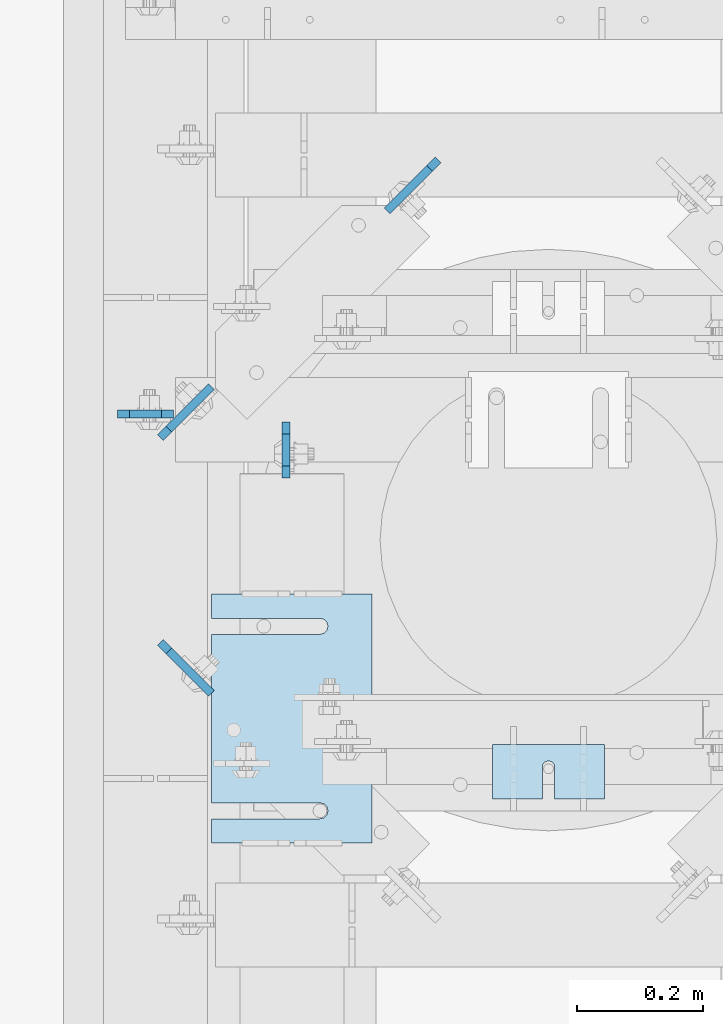
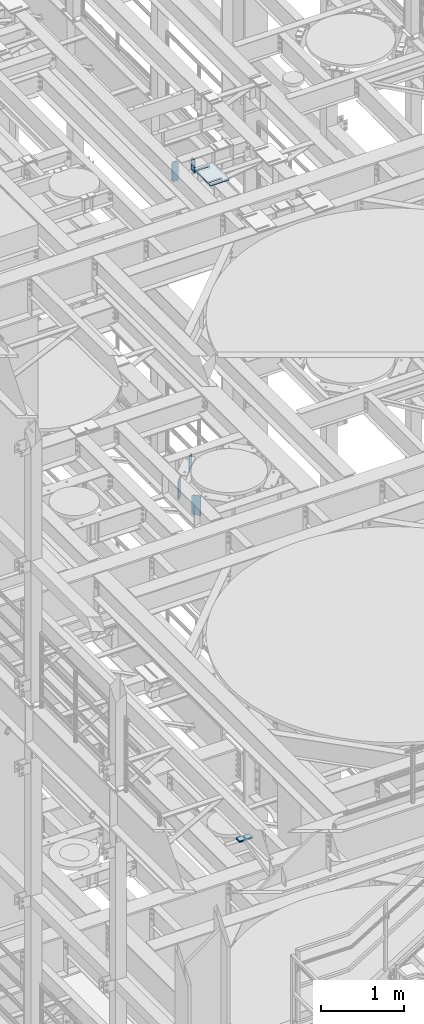
# One storey, part 1637 of 1876: 12 plates, 11 elements without a shape of their own.
"""IFC2X3 building model written with IfcOpenShell, lengths in millimetres."""

from ifc_helpers import new_model, si_unit, frame, origin_with_axes, place, context, subcontext, project, spatial, faceted_brep, material, type_object, element, aggregate, save


model = new_model("IFC2X3")

# Units and contexts
model_context = context("Model", 3, precision=1e-05, world=origin_with_axes())
body_context = subcontext(model_context, "Body", "Model", "MODEL_VIEW")
ifc_project = project(units=[si_unit("LENGTHUNIT", "METRE", prefix="MILLI"), si_unit("AREAUNIT", "SQUARE_METRE"), si_unit("VOLUMEUNIT", "CUBIC_METRE"), si_unit("MASSUNIT", "GRAM", prefix="KILO"), si_unit("TIMEUNIT", "SECOND"), si_unit("PLANEANGLEUNIT", "RADIAN"), si_unit("SOLIDANGLEUNIT", "STERADIAN"), si_unit("THERMODYNAMICTEMPERATUREUNIT", "DEGREE_CELSIUS"), si_unit("LUMINOUSINTENSITYUNIT", "LUMEN")], contexts=[model_context])

# Site, building, storey
site_placement = place(None, origin_with_axes())
site = spatial("IfcSite", under=ifc_project, at=site_placement, CompositionType="ELEMENT")
building_placement = place(site_placement, origin_with_axes())
building = spatial("IfcBuilding", under=site, at=building_placement, Name="Undefined", CompositionType="ELEMENT")
storey_placement = place(building_placement, origin_with_axes())
storey = spatial("IfcBuildingStorey", under=building, at=storey_placement, Name="Undefined", CompositionType="ELEMENT", Elevation=0.0)

# Assembly, plate
assembly_1_placement = place(storey_placement, origin_with_axes())
assembly_1 = element("IfcElementAssembly", 1, at=assembly_1_placement, inside=storey, Name="SHIM PLATE", AssemblyPlace="NOTDEFINED", PredefinedType="RIGID_FRAME")
ifc_material = material(Name="STEEL/A36")
plate_type_1 = type_object("IfcPlateType", PredefinedType="NOTDEFINED")
plate_1_placement = place(assembly_1_placement, frame((4508.50086692662, 2117.72232666016, 8158.1625), z_axis=(0.0, -1.0, 0.0), x_axis=(-1.0, 0.0, 0.0)))
plate_1 = element("IfcPlate", 2, at=plate_1_placement, type_object=plate_type_1, material=ifc_material, Name="SHIM PLATE", context=body_context, shape_type="Brep", body=[
    faceted_brep([(79.3754980174272, -4.76249999999982, 85.7959442138672), (79.3816870943956, -4.76249999999982, 38.1942513122049), (79.3816870943956, 4.76249999999982, 38.1942513122049), (79.3754980174272, 4.76249999999982, 85.7959442138672), (79.5339603115162, -4.76249999999982, 32.1592455981272), (79.5339603115162, 4.76249999999982, 32.1592455981272), (83.1558903074947, -4.76249999999982, 27.3295350264834), (83.1558903074947, 4.76249999999982, 27.3295350264834), (88.9066875296403, -4.76249999999982, 25.4930132021109), (88.9066875296403, 4.76249999999982, 25.4930132021109), (94.6574845388659, -4.76249999999982, 27.3295356932131), (94.6574845388659, 4.76249999999982, 27.3295356932131), (98.2794139749021, -4.76249999999982, 32.1592466847724), (98.2794139749021, 4.76249999999982, 32.1592466847724), (98.4316864923421, -4.76249999999982, 38.1942524165047), (98.4316864923421, 4.76249999999982, 38.1942524165047), (98.4254974155128, -4.76249999999982, 85.7959442138635), (98.4254974155128, 4.76249999999982, 85.7959442138672), (0.0, -4.76249999999982, 0.0), (0.0, -4.76249999999982, 85.7959442138672), (0.0, 4.76249999999982, 85.7959442138672), (0.0, 4.76249999999982, 0.0), (177.800994873047, -4.76249999999982, 0.0), (177.800994873047, 4.76249999999982, 0.0), (177.800994873047, -4.76249999999982, 85.7959442138672), (177.800994873047, 4.76249999999982, 85.7959442138672)], [[[0, 1, 2, 3]], [[4, 5, 2, 1]], [[6, 7, 5, 4]], [[8, 9, 7, 6]], [[10, 11, 9, 8]], [[12, 13, 11, 10]], [[14, 15, 13, 12]], [[16, 17, 15, 14]], [[18, 19, 20, 21]], [[22, 18, 21, 23]], [[24, 22, 23, 25]], [[12, 10, 8, 6, 4, 1, 0, 19, 18, 22, 24, 16, 14]], [[20, 19, 0, 3]], [[25, 23, 21, 20, 3, 2, 5, 7, 9, 11, 13, 15, 17]], [[24, 25, 17, 16]]]),
])
aggregate(assembly_1, [plate_1])

assembly_2_placement = place(storey_placement, origin_with_axes())
assembly_2 = element("IfcElementAssembly", 3, at=assembly_2_placement, inside=storey, Name="BEAM", AssemblyPlace="NOTDEFINED", PredefinedType="RIGID_FRAME")
plate_type_2 = type_object("IfcPlateType", PredefinedType="NOTDEFINED")
plate_2_placement = place(assembly_2_placement, frame((4003.67517775661, 2628.8994140625, 17786.35), z_axis=(0.0, 0.0, 1.0), x_axis=(0.0, -1.0, 0.0)))
plate_2 = element("IfcPlate", 4, at=plate_2_placement, type_object=plate_type_2, material=ifc_material, Name="PLATE", context=body_context, shape_type="Brep", body=[
    faceted_brep([(0.0, -6.35000000000196, 19.0499992370605), (0.0, -6.34999999999991, 169.862506866455), (0.0, 6.34999999999991, 169.862506866455), (0.0, 6.35000000000105, 19.0499992370605), (19.0499992370605, -6.34999999999991, 188.912506103516), (19.0499992370605, 6.34999999999991, 188.912506103516), (69.8500022888184, -6.34999999999991, 188.912506103516), (69.8500022888184, 6.34999999999991, 188.912506103516), (88.9000015258789, -6.34999999999991, 169.862506866455), (88.9000015258789, 6.34999999999991, 169.862506866455), (88.9000015258789, -6.34999999999991, 0.0), (88.9000015258789, 6.34999999999991, 0.0), (19.0499992370642, -6.35000000000105, 0.0), (19.0499992370633, 6.35000000000105, 0.0)], [[[0, 1, 2, 3]], [[1, 4, 5, 2]], [[4, 6, 7, 5]], [[6, 8, 9, 7]], [[8, 10, 11, 9]], [[10, 12, 13, 11]], [[12, 0, 3, 13]], [[5, 7, 9, 11, 13, 3, 2]], [[12, 10, 8, 6, 4, 1, 0]]]),
])
aggregate(assembly_2, [plate_2])

assembly_3_placement = place(storey_placement, origin_with_axes())
assembly_3 = element("IfcElementAssembly", 5, at=assembly_3_placement, inside=storey, Name="BEAM", AssemblyPlace="NOTDEFINED", PredefinedType="RIGID_FRAME")
plate_3_placement = place(assembly_3_placement, frame((3736.975, 2641.59941415787, 17683.1625), z_axis=(0.0, 0.0, 1.0), x_axis=(1.0, 0.0, 0.0)))
plate_3 = element("IfcPlate", 6, at=plate_3_placement, type_object=plate_type_2, material=ifc_material, Name="PLATE", context=body_context, shape_type="Brep", body=[
    faceted_brep([(0.0, -6.35000000000196, 19.0499992370605), (0.0, -6.35000000000036, 271.462512969971), (0.0, 6.35000000000036, 271.462512969971), (0.0, 6.35000000000105, 19.0499992370605), (19.0499992370605, -6.35000000000036, 290.512512207031), (19.0499992370605, 6.35000000000036, 290.512512207031), (69.8500003814697, -6.34999999999991, 290.512512207031), (69.8500003814697, 6.34999999999991, 290.512512207031), (88.9000015258789, -6.35000000000036, 271.462512969971), (88.9000015258789, 6.35000000000036, 271.462512969971), (88.9000015258789, -6.34999999999991, 0.0), (88.9000015258789, 6.34999999999991, 0.0), (19.0499992370642, -6.35000000000105, 0.0), (19.0499992370633, 6.35000000000105, 0.0)], [[[0, 1, 2, 3]], [[1, 4, 5, 2]], [[4, 6, 7, 5]], [[6, 8, 9, 7]], [[8, 10, 11, 9]], [[10, 12, 13, 11]], [[12, 0, 3, 13]], [[5, 7, 9, 11, 13, 3, 2]], [[12, 10, 8, 6, 4, 1, 0]]]),
])
aggregate(assembly_3, [plate_3])

assembly_4_placement = place(storey_placement, origin_with_axes())
assembly_4 = element("IfcElementAssembly", 7, at=assembly_4_placement, inside=storey, Name="SHIM PLATE", AssemblyPlace="NOTDEFINED", PredefinedType="RIGID_FRAME")
plate_type_3 = type_object("IfcPlateType", PredefinedType="NOTDEFINED")
plate_4_placement = place(assembly_4_placement, frame((4508.50086692662, 2117.72232666016, 8179.5925), z_axis=(0.0, -1.0, 0.0), x_axis=(-1.0, 0.0, 0.0)))
plate_4 = element("IfcPlate", 8, at=plate_4_placement, type_object=plate_type_3, material=ifc_material, Name="SHIM PLATE", context=body_context, shape_type="Brep", body=[
    faceted_brep([(79.3754980174272, -0.793499999999767, 85.7959442138672), (79.3816870943956, -0.793499999999767, 38.1942513122049), (79.3816870943956, 0.793499999999767, 38.1942513122049), (79.3754980174272, 0.793499999999767, 85.7959442138672), (79.5339603115162, -0.793499999999767, 32.1592455981272), (79.5339603115162, 0.793499999999767, 32.1592455981272), (83.1558903074947, -0.793499999999767, 27.3295350264834), (83.1558903074947, 0.793499999999767, 27.3295350264834), (88.9066875296403, -0.793499999999767, 25.4930132021109), (88.9066875296403, 0.793499999999767, 25.4930132021109), (94.6574845388659, -0.793499999999767, 27.3295356932131), (94.6574845388659, 0.793499999999767, 27.3295356932131), (98.2794139749021, -0.793499999999767, 32.1592466847724), (98.2794139749021, 0.793499999999767, 32.1592466847724), (98.4316864923421, -0.793499999999767, 38.1942524165047), (98.4316864923421, 0.793499999999767, 38.1942524165047), (98.4254974155128, -0.793499999999767, 85.7959442138635), (98.4254974155128, 0.793499999999767, 85.7959442138672), (9.09494701772928e-13, -0.793499999999767, 0.0), (0.0, -0.793499999999767, 85.7959442138672), (0.0, 0.793499999999767, 85.7959442138672), (9.09494701772928e-13, 0.793499999999767, 0.0), (177.800994873047, -0.793499999999767, 0.0), (177.800994873047, 0.793499999999767, 0.0), (177.800994873047, -0.793499999999767, 85.7959442138672), (177.800994873047, 0.793499999999767, 85.7959442138672)], [[[0, 1, 2, 3]], [[4, 5, 2, 1]], [[6, 7, 5, 4]], [[8, 9, 7, 6]], [[10, 11, 9, 8]], [[12, 13, 11, 10]], [[14, 15, 13, 12]], [[16, 17, 15, 14]], [[18, 19, 20, 21]], [[22, 18, 21, 23]], [[24, 22, 23, 25]], [[12, 10, 8, 6, 4, 1, 0, 19, 18, 22, 24, 16, 14]], [[20, 19, 0, 3]], [[25, 23, 21, 20, 3, 2, 5, 7, 9, 11, 13, 15, 17]], [[24, 25, 17, 16]]]),
])
aggregate(assembly_4, [plate_4])

assembly_5_placement = place(storey_placement, origin_with_axes())
assembly_5 = element("IfcElementAssembly", 9, at=assembly_5_placement, inside=storey, Name="SHIM PLATE", AssemblyPlace="NOTDEFINED", PredefinedType="RIGID_FRAME")
plate_type_4 = type_object("IfcPlateType", PredefinedType="NOTDEFINED")
plate_5_placement = place(assembly_5_placement, frame((4508.50086692662, 2117.72232666016, 8177.2115), z_axis=(0.0, -1.0, 0.0), x_axis=(-1.0, 0.0, 0.0)))
plate_5 = element("IfcPlate", 10, at=plate_5_placement, type_object=plate_type_4, material=ifc_material, Name="SHIM PLATE", context=body_context, shape_type="Brep", body=[
    faceted_brep([(79.3754980174272, -1.58749999999964, 85.7959442138672), (79.3816870943956, -1.58749999999964, 38.1942513122049), (79.3816870943956, 1.58749999999964, 38.1942513122049), (79.3754980174272, 1.58749999999964, 85.7959442138672), (79.5339603115162, -1.58749999999964, 32.1592455981272), (79.5339603115162, 1.58749999999964, 32.1592455981272), (83.1558903074947, -1.58749999999964, 27.3295350264834), (83.1558903074947, 1.58749999999964, 27.3295350264834), (88.9066875296403, -1.58749999999964, 25.4930132021109), (88.9066875296403, 1.58749999999964, 25.4930132021109), (94.6574845388659, -1.58749999999964, 27.3295356932131), (94.6574845388659, 1.58749999999964, 27.3295356932131), (98.2794139749021, -1.58749999999964, 32.1592466847724), (98.2794139749021, 1.58749999999964, 32.1592466847724), (98.4316864923421, -1.58749999999964, 38.1942524165047), (98.4316864923421, 1.58749999999964, 38.1942524165047), (98.4254974155128, -1.58749999999964, 85.7959442138635), (98.4254974155128, 1.58749999999964, 85.7959442138672), (9.09494701772928e-13, -1.58750000000146, 4.54747350886464e-13), (0.0, -1.58749999999964, 85.7959442138672), (0.0, 1.58749999999964, 85.7959442138672), (9.09494701772928e-13, 1.58750000000146, 4.54747350886464e-13), (177.800994873047, -1.58749999999964, 0.0), (177.800994873047, 1.58749999999964, 0.0), (177.800994873047, -1.58749999999964, 85.7959442138672), (177.800994873047, 1.58749999999964, 85.7959442138672)], [[[0, 1, 2, 3]], [[4, 5, 2, 1]], [[6, 7, 5, 4]], [[8, 9, 7, 6]], [[10, 11, 9, 8]], [[12, 13, 11, 10]], [[14, 15, 13, 12]], [[16, 17, 15, 14]], [[18, 19, 20, 21]], [[22, 18, 21, 23]], [[24, 22, 23, 25]], [[12, 10, 8, 6, 4, 1, 0, 19, 18, 22, 24, 16, 14]], [[20, 19, 0, 3]], [[25, 23, 21, 20, 3, 2, 5, 7, 9, 11, 13, 15, 17]], [[24, 25, 17, 16]]]),
])
aggregate(assembly_5, [plate_5])

assembly_6_placement = place(storey_placement, origin_with_axes())
assembly_6 = element("IfcElementAssembly", 11, at=assembly_6_placement, inside=storey, Name="SHIM PLATE", AssemblyPlace="NOTDEFINED", PredefinedType="RIGID_FRAME")
plate_6_placement = place(assembly_6_placement, frame((4508.50086692662, 2117.72232666016, 8174.0365), z_axis=(0.0, -1.0, 0.0), x_axis=(-1.0, 0.0, 0.0)))
plate_6 = element("IfcPlate", 12, at=plate_6_placement, type_object=plate_type_4, material=ifc_material, Name="SHIM PLATE", context=body_context, shape_type="Brep", body=[
    faceted_brep([(79.3754980174272, -1.58749999999964, 85.7959442138672), (79.3816870943956, -1.58749999999964, 38.1942513122049), (79.3816870943956, 1.58749999999964, 38.1942513122049), (79.3754980174272, 1.58749999999964, 85.7959442138672), (79.5339603115162, -1.58749999999964, 32.1592455981272), (79.5339603115162, 1.58749999999964, 32.1592455981272), (83.1558903074947, -1.58749999999964, 27.3295350264834), (83.1558903074947, 1.58749999999964, 27.3295350264834), (88.9066875296403, -1.58749999999964, 25.4930132021109), (88.9066875296403, 1.58749999999964, 25.4930132021109), (94.6574845388659, -1.58749999999964, 27.3295356932131), (94.6574845388659, 1.58749999999964, 27.3295356932131), (98.2794139749021, -1.58749999999964, 32.1592466847724), (98.2794139749021, 1.58749999999964, 32.1592466847724), (98.4316864923421, -1.58749999999964, 38.1942524165047), (98.4316864923421, 1.58749999999964, 38.1942524165047), (98.4254974155128, -1.58749999999964, 85.7959442138635), (98.4254974155128, 1.58749999999964, 85.7959442138672), (9.09494701772928e-13, -1.58750000000146, 4.54747350886464e-13), (0.0, -1.58749999999964, 85.7959442138672), (0.0, 1.58749999999964, 85.7959442138672), (9.09494701772928e-13, 1.58750000000146, 4.54747350886464e-13), (177.800994873047, -1.58749999999964, 0.0), (177.800994873047, 1.58749999999964, 0.0), (177.800994873047, -1.58749999999964, 85.7959442138672), (177.800994873047, 1.58749999999964, 85.7959442138672)], [[[0, 1, 2, 3]], [[4, 5, 2, 1]], [[6, 7, 5, 4]], [[8, 9, 7, 6]], [[10, 11, 9, 8]], [[12, 13, 11, 10]], [[14, 15, 13, 12]], [[16, 17, 15, 14]], [[18, 19, 20, 21]], [[22, 18, 21, 23]], [[24, 22, 23, 25]], [[12, 10, 8, 6, 4, 1, 0, 19, 18, 22, 24, 16, 14]], [[20, 19, 0, 3]], [[25, 23, 21, 20, 3, 2, 5, 7, 9, 11, 13, 15, 17]], [[24, 25, 17, 16]]]),
])
aggregate(assembly_6, [plate_6])

assembly_7_placement = place(storey_placement, origin_with_axes())
assembly_7 = element("IfcElementAssembly", 13, at=assembly_7_placement, inside=storey, Name="SHIM PLATE", AssemblyPlace="NOTDEFINED", PredefinedType="RIGID_FRAME")
plate_type_5 = type_object("IfcPlateType", PredefinedType="NOTDEFINED")
plate_7_placement = place(assembly_7_placement, frame((4508.50086692662, 2117.72232666016, 8170.068), z_axis=(0.0, -1.0, 0.0), x_axis=(-1.0, 0.0, 0.0)))
plate_7 = element("IfcPlate", 14, at=plate_7_placement, type_object=plate_type_5, material=ifc_material, Name="SHIM PLATE", context=body_context, shape_type="Brep", body=[
    faceted_brep([(79.3754980174272, -2.38100000000031, 85.7959442138672), (79.3816870943956, -2.38100000000031, 38.1942513122049), (79.3816870943956, 2.38100000000031, 38.1942513122049), (79.3754980174272, 2.38100000000031, 85.7959442138672), (79.5339603115162, -2.38100000000031, 32.1592455981272), (79.5339603115162, 2.38100000000031, 32.1592455981272), (83.1558903074947, -2.38100000000031, 27.3295350264834), (83.1558903074947, 2.38100000000031, 27.3295350264834), (88.9066875296403, -2.38100000000031, 25.4930132021109), (88.9066875296403, 2.38100000000031, 25.4930132021109), (94.6574845388659, -2.38100000000031, 27.3295356932131), (94.6574845388659, 2.38100000000031, 27.3295356932131), (98.2794139749021, -2.38100000000031, 32.1592466847724), (98.2794139749021, 2.38100000000031, 32.1592466847724), (98.4316864923421, -2.38100000000031, 38.1942524165047), (98.4316864923421, 2.38100000000031, 38.1942524165047), (98.4254974155128, -2.38100000000031, 85.7959442138635), (98.4254974155128, 2.38100000000031, 85.7959442138672), (0.0, -2.38100000000122, 4.54747350886464e-13), (0.0, -2.38100000000031, 85.7959442138672), (0.0, 2.38100000000031, 85.7959442138672), (0.0, 2.38100000000122, 4.54747350886464e-13), (177.800994873047, -2.38100000000031, 0.0), (177.800994873047, 2.38100000000031, 0.0), (177.800994873047, -2.38100000000031, 85.7959442138672), (177.800994873047, 2.38100000000031, 85.7959442138672)], [[[0, 1, 2, 3]], [[4, 5, 2, 1]], [[6, 7, 5, 4]], [[8, 9, 7, 6]], [[10, 11, 9, 8]], [[12, 13, 11, 10]], [[14, 15, 13, 12]], [[16, 17, 15, 14]], [[18, 19, 20, 21]], [[22, 18, 21, 23]], [[24, 22, 23, 25]], [[12, 10, 8, 6, 4, 1, 0, 19, 18, 22, 24, 16, 14]], [[20, 19, 0, 3]], [[25, 23, 21, 20, 3, 2, 5, 7, 9, 11, 13, 15, 17]], [[24, 25, 17, 16]]]),
])
aggregate(assembly_7, [plate_7])

assembly_8_placement = place(storey_placement, origin_with_axes())
assembly_8 = element("IfcElementAssembly", 15, at=assembly_8_placement, inside=storey, Name="SHIM PLATE", AssemblyPlace="NOTDEFINED", PredefinedType="RIGID_FRAME")
plate_8_placement = place(assembly_8_placement, frame((4508.50086692662, 2117.72232666016, 8165.306), z_axis=(0.0, -1.0, 0.0), x_axis=(-1.0, 0.0, 0.0)))
plate_8 = element("IfcPlate", 16, at=plate_8_placement, type_object=plate_type_5, material=ifc_material, Name="SHIM PLATE", context=body_context, shape_type="Brep", body=[
    faceted_brep([(79.3754980174272, -2.38100000000031, 85.7959442138672), (79.3816870943956, -2.38100000000031, 38.1942513122049), (79.3816870943956, 2.38100000000031, 38.1942513122049), (79.3754980174272, 2.38100000000031, 85.7959442138672), (79.5339603115162, -2.38100000000031, 32.1592455981272), (79.5339603115162, 2.38100000000031, 32.1592455981272), (83.1558903074947, -2.38100000000031, 27.3295350264834), (83.1558903074947, 2.38100000000031, 27.3295350264834), (88.9066875296403, -2.38100000000031, 25.4930132021109), (88.9066875296403, 2.38100000000031, 25.4930132021109), (94.6574845388659, -2.38100000000031, 27.3295356932131), (94.6574845388659, 2.38100000000031, 27.3295356932131), (98.2794139749021, -2.38100000000031, 32.1592466847724), (98.2794139749021, 2.38100000000031, 32.1592466847724), (98.4316864923421, -2.38100000000031, 38.1942524165047), (98.4316864923421, 2.38100000000031, 38.1942524165047), (98.4254974155128, -2.38100000000031, 85.7959442138635), (98.4254974155128, 2.38100000000031, 85.7959442138672), (0.0, -2.38100000000122, 4.54747350886464e-13), (0.0, -2.38100000000031, 85.7959442138672), (0.0, 2.38100000000031, 85.7959442138672), (0.0, 2.38100000000122, 4.54747350886464e-13), (177.800994873047, -2.38100000000031, 0.0), (177.800994873047, 2.38100000000031, 0.0), (177.800994873047, -2.38100000000031, 85.7959442138672), (177.800994873047, 2.38100000000031, 85.7959442138672)], [[[0, 1, 2, 3]], [[4, 5, 2, 1]], [[6, 7, 5, 4]], [[8, 9, 7, 6]], [[10, 11, 9, 8]], [[12, 13, 11, 10]], [[14, 15, 13, 12]], [[16, 17, 15, 14]], [[18, 19, 20, 21]], [[22, 18, 21, 23]], [[24, 22, 23, 25]], [[12, 10, 8, 6, 4, 1, 0, 19, 18, 22, 24, 16, 14]], [[20, 19, 0, 3]], [[25, 23, 21, 20, 3, 2, 5, 7, 9, 11, 13, 15, 17]], [[24, 25, 17, 16]]]),
])
aggregate(assembly_8, [plate_8])

assembly_9_placement = place(storey_placement, origin_with_axes())
assembly_9 = element("IfcElementAssembly", 17, at=assembly_9_placement, inside=storey, Name="SHIM PLATE", AssemblyPlace="NOTDEFINED", PredefinedType="RIGID_FRAME")
plate_type_6 = type_object("IfcPlateType", PredefinedType="NOTDEFINED")
plate_9_placement = place(assembly_9_placement, frame((4140.19755067568, 1962.15311651737, 17987.9625), z_axis=(-1.0, 0.0, 0.0), x_axis=(0.0, 1.0, 0.0)))
plate_9 = element("IfcPlate", 18, at=plate_9_placement, type_object=plate_type_6, material=ifc_material, Name="SHIM PLATE", context=body_context, shape_type="Brep", body=[
    faceted_brep([(38.0954210666328, -4.76250000000073, 253.999557495103), (38.0976431969724, -4.76250000000073, 82.6182312417654), (38.0976431969724, 4.76250000000073, 82.6182312417654), (38.0954210666328, 4.76250000000073, 253.999557495103), (39.7991131045027, -4.76250000000073, 76.2682279470096), (39.7991131045027, 4.76250000000073, 76.2682279470096), (44.4476316136985, -4.76250000000073, 71.6196994315187), (44.4476316136985, 4.76250000000073, 71.6196994315187), (50.7976312458977, -4.76250000000073, 69.9182158551362), (50.7976312458977, 4.76250000000073, 69.9182158551362), (57.1476337740625, -4.76250000000073, 71.6196886236189), (57.1476337740625, 4.76250000000073, 71.6196886236189), (61.7961601951824, -4.76250000000073, 76.2682092271793), (61.7961601951824, 4.76250000000073, 76.2682092271793), (63.497640910601, -4.76250000000073, 82.6182096259718), (63.497640910601, 4.76250000000073, 82.6182096259718), (63.4954187799489, -4.76250000000073, 253.999557267866), (63.4954187799489, 4.76250000000073, 253.999557495093), (0.0, -4.76249999999982, 0.0), (1.89073648471094e-05, -4.76250000000073, 253.999557495117), (1.89073648471094e-05, 4.76250000000073, 253.999557495117), (0.0, 4.76249999999982, 0.0), (393.698486328125, -4.76250000000073, -1.41881173476577e-10), (393.698486328125, 4.76250000000073, -1.41881173476577e-10), (393.698516845714, -4.76250000000073, 253.999557494967), (393.698516845714, 4.76250000000073, 253.999557494967), (355.593905292273, 4.76250000000073, 253.999557494981), (355.593905292273, -4.76250000000073, 253.999558194833), (355.596127251301, 4.76250000000073, 82.6182258117283), (355.596127251301, -4.76250000000073, 82.6182258117283), (353.894652887411, 4.76250000000073, 76.2682211679371), (353.894652887411, -4.76250000000073, 76.2682211679371), (349.246128913514, 4.76250000000073, 71.6196946431969), (349.246128913514, -4.76250000000073, 71.6196946431969), (342.896125203397, 4.76250000000073, 69.9182167947934), (342.896125203397, -4.76250000000073, 69.9182167947934), (336.546122348359, 4.76250000000073, 71.6196978343955), (336.546122348359, -4.76250000000073, 71.6196978343955), (331.897600710579, 4.76250000000073, 76.2682266952543), (331.897600710579, -4.76250000000073, 76.2682266952543), (330.196129537885, 4.76250000000073, 82.6182321941214), (330.196129537885, -4.76250000000073, 82.6182321941214), (330.193907578964, -4.76250000000073, 253.999557494991), (330.193907578964, 4.76250000000073, 253.999557494991)], [[[0, 1, 2, 3]], [[4, 5, 2, 1]], [[6, 7, 5, 4]], [[8, 9, 7, 6]], [[10, 11, 9, 8]], [[12, 13, 11, 10]], [[14, 15, 13, 12]], [[16, 17, 15, 14]], [[18, 19, 20, 21]], [[22, 18, 21, 23]], [[24, 22, 23, 25]], [[24, 25, 26, 27]], [[27, 26, 28, 29]], [[29, 28, 30, 31]], [[31, 30, 32, 33]], [[33, 32, 34, 35]], [[35, 34, 36, 37]], [[37, 36, 38, 39]], [[39, 38, 40, 41]], [[42, 41, 40, 43]], [[12, 10, 8, 6, 4, 1, 0, 19, 18, 22, 24, 27, 29, 31, 33, 35, 37, 39, 41, 42, 16, 14]], [[20, 19, 0, 3]], [[43, 40, 38, 36, 34, 32, 30, 28, 26, 25, 23, 21, 20, 3, 2, 5, 7, 9, 11, 13, 15, 17]], [[42, 43, 17, 16]]]),
])
aggregate(assembly_9, [plate_9])

# Assembly, plates
assembly_10_placement = place(storey_placement, origin_with_axes())
assembly_10 = element("IfcElementAssembly", 19, at=assembly_10_placement, inside=storey, Name="BEAM", AssemblyPlace="NOTDEFINED", PredefinedType="RIGID_FRAME")
plate_type_7 = type_object("IfcPlateType", PredefinedType="NOTDEFINED")
plate_10_placement = place(assembly_10_placement, frame((3804.96514502377, 2279.41861777872, 13007.975), z_axis=(0.0, 0.0, 1.0), x_axis=(0.707104099181461, -0.707109463181462, 0.0)))
plate_10 = element("IfcPlate", 20, at=plate_10_placement, type_object=plate_type_7, material=ifc_material, Name="PLATE", context=body_context, shape_type="Brep", body=[
    faceted_brep([(0.0, -6.35000000000196, 19.0499992370605), (0.0, -6.35000000000036, 271.462512969971), (0.0, 6.35000000000036, 271.462512969971), (0.0, 6.35000000000105, 19.0499992370605), (19.0499992370605, -6.35000000000036, 290.512512207031), (19.0499992370605, 6.35000000000036, 290.512512207031), (114.300003051753, -6.35000000000946, 290.512512207031), (114.300003051755, 6.34999999999036, 290.512512207031), (114.300003051752, -6.34999999998786, 0.0), (114.300003051755, 6.35000000000741, 0.0), (19.0499992370642, -6.35000000000105, 0.0), (19.0499992370633, 6.35000000000105, 0.0)], [[[0, 1, 2, 3]], [[1, 4, 5, 2]], [[4, 6, 7, 5]], [[6, 8, 9, 7]], [[8, 10, 11, 9]], [[10, 0, 3, 11]], [[5, 7, 9, 11, 3, 2]], [[10, 8, 6, 4, 1, 0]]]),
])
plate_11_placement = place(assembly_10_placement, frame((3804.96514502377, 2603.73138222135, 13007.975), z_axis=(0.0, 0.0, 1.0), x_axis=(0.707104099181461, 0.707109463181462, 0.0)))
plate_11 = element("IfcPlate", 21, at=plate_11_placement, type_object=plate_type_7, material=ifc_material, Name="PLATE", context=body_context, shape_type="Brep", body=[
    faceted_brep([(0.0, -6.35000000000196, 19.0499992370605), (0.0, -6.35000000000036, 271.462512969971), (0.0, 6.35000000000036, 271.462512969971), (0.0, 6.35000000000105, 19.0499992370605), (19.0499992370605, -6.35000000000036, 290.512512207031), (19.0499992370605, 6.35000000000036, 290.512512207031), (114.300003051753, -6.35000000000946, 290.512512207031), (114.300003051755, 6.34999999999036, 290.512512207031), (114.300003051752, -6.34999999998786, 0.0), (114.300003051755, 6.35000000000741, 0.0), (19.0499992370642, -6.35000000000105, 0.0), (19.0499992370633, 6.35000000000105, 0.0)], [[[0, 1, 2, 3]], [[1, 4, 5, 2]], [[4, 6, 7, 5]], [[6, 8, 9, 7]], [[8, 10, 11, 9]], [[10, 0, 3, 11]], [[5, 7, 9, 11, 3, 2]], [[10, 8, 6, 4, 1, 0]]]),
])
aggregate(assembly_10, [plate_10, plate_11])

# Assembly, plate
assembly_11_placement = place(storey_placement, origin_with_axes())
assembly_11 = element("IfcElementAssembly", 22, at=assembly_11_placement, inside=storey, Name="BEAM", AssemblyPlace="NOTDEFINED", PredefinedType="RIGID_FRAME")
plate_12_placement = place(assembly_11_placement, frame((4244.74031576252, 3043.50988903762, 13112.75), z_axis=(0.0, 0.0, 1.0), x_axis=(-0.707104099181461, -0.707109463181462, 0.0)))
plate_12 = element("IfcPlate", 23, at=plate_12_placement, type_object=plate_type_7, material=ifc_material, Name="PLATE", context=body_context, shape_type="Brep", body=[
    faceted_brep([(0.0, -6.35000000000196, 19.0499992370605), (0.0, -6.34999999999991, 169.862506866455), (0.0, 6.34999999999991, 169.862506866455), (0.0, 6.35000000000105, 19.0499992370605), (19.0499992370605, -6.34999999999991, 188.912506103516), (19.0499992370605, 6.34999999999991, 188.912506103516), (114.300003051752, -6.34999999998786, 188.912506103516), (114.300003051755, 6.35000000000741, 188.912506103516), (114.300003051752, -6.34999999998786, 0.0), (114.300003051755, 6.35000000000741, 0.0), (19.0499992370642, -6.35000000000105, 0.0), (19.0499992370633, 6.35000000000105, 0.0)], [[[0, 1, 2, 3]], [[1, 4, 5, 2]], [[4, 6, 7, 5]], [[6, 8, 9, 7]], [[8, 10, 11, 9]], [[10, 0, 3, 11]], [[5, 7, 9, 11, 3, 2]], [[10, 8, 6, 4, 1, 0]]]),
])
aggregate(assembly_11, [plate_12])

save(model, "model.ifc")
